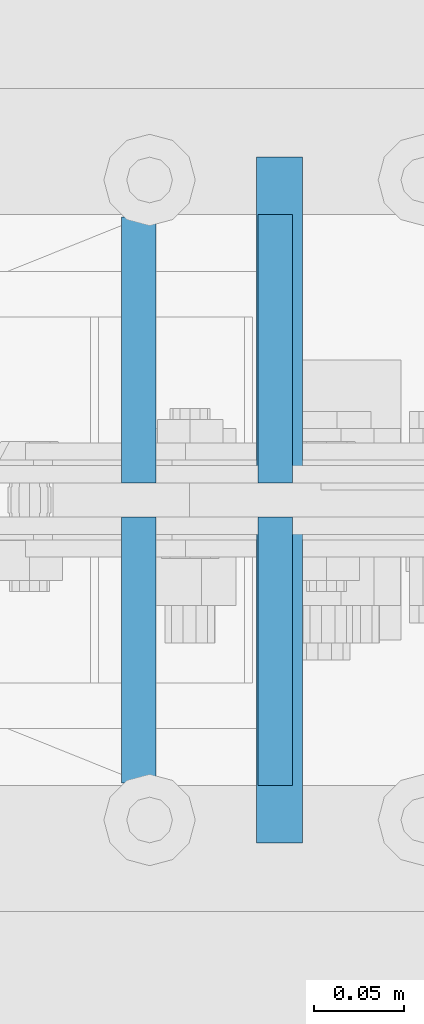
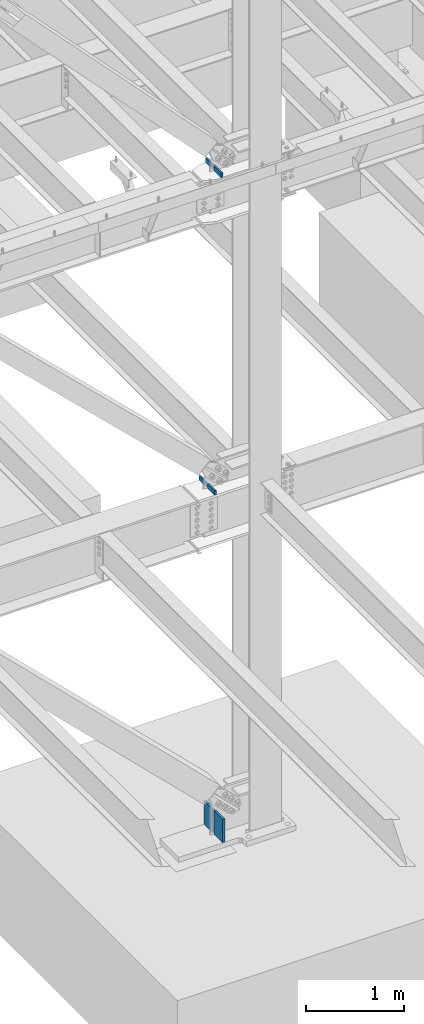
# One storey, part 456 of 1179: 6 columns, 3 elements without a shape of their own.
"""IFC2X3 building model written with IfcOpenShell, lengths in millimetres."""

import ifcopenshell
import ifcopenshell.guid

model = None  # the IFC model being written
_history = None  # IfcOwnerHistory: only IFC2X3 demands one
_inside = {}  # id of a spatial element -> (the spatial element, [elements in it])
_under = {}  # id of a project, library or spatial element -> (it, [spatial elements below it])
_declared = {}  # id of a project -> (the project, [libraries it declares])
_typed = {}  # id of a type object -> (the type object, [elements of that type])
_made_of = {}  # id of a material, layer set ... -> (it, [elements and type objects made of it])


def new_model(schema):
    """Start an empty IFC model of exactly this schema.

    Asked for "IFC4X3", IfcOpenShell would pick the latest addendum, in which some entities
    have other attributes; the version numbers below select the first issue.
    IFC2X3 requires an IfcOwnerHistory on every rooted entity: one is made here for all.
    """
    global model, _history
    if schema == "IFC4X3":
        model = ifcopenshell.file(schema_version=(4, 3, 0, 0))
    else:
        model = ifcopenshell.file(schema=schema)
    _inside.clear()
    _under.clear()
    _declared.clear()
    _typed.clear()
    _made_of.clear()
    _history = None
    if model.schema == "IFC2X3":
        org = make("IfcOrganization", Name="unknown")
        user = make(
            "IfcPersonAndOrganization",
            ThePerson=make("IfcPerson", FamilyName="unknown"),
            TheOrganization=org,
        )
        app = make(
            "IfcApplication",
            ApplicationDeveloper=org,
            Version="unknown",
            ApplicationFullName="unknown",
            ApplicationIdentifier="unknown",
        )
        _history = make(
            "IfcOwnerHistory",
            OwningUser=user,
            OwningApplication=app,
            ChangeAction="ADDED",
            CreationDate=0,
        )
    return model


def make(cls, **values):
    """One entity of the class cls with the attributes given. An attribute that is None is left unset."""
    return model.create_entity(
        cls, **{name: value for name, value in values.items() if value is not None}
    )


def rooted(cls, **values):
    """An entity with a GlobalId (a new one), such as an element, a storey or a relation."""
    return make(cls, GlobalId=ifcopenshell.guid.new(), OwnerHistory=_history, **values)


def si_unit(unit_type, name, prefix=None):
    """IfcSIUnit, for example si_unit("LENGTHUNIT", "METRE", prefix="MILLI")."""
    return make("IfcSIUnit", UnitType=unit_type, Prefix=prefix, Name=name)


def assignment(units):
    """IfcUnitAssignment: the units of a project."""
    return None if units is None else make("IfcUnitAssignment", Units=units)


def point(xyz):
    """IfcCartesianPoint."""
    return None if xyz is None else make("IfcCartesianPoint", Coordinates=xyz)


def direction(xyz):
    """IfcDirection."""
    return None if xyz is None else make("IfcDirection", DirectionRatios=xyz)


def frame(location, z_axis=None, x_axis=None):
    """IfcAxis2Placement3D, a coordinate frame: its origin and axes. An axis left out is left unset."""
    return make(
        "IfcAxis2Placement3D",
        Location=point(location),
        Axis=direction(z_axis),
        RefDirection=direction(x_axis),
    )


def origin_with_axes():
    """The frame at (0, 0, 0) with the z axis (0, 0, 1) and the x axis (1, 0, 0) written out."""
    return frame((0.0, 0.0, 0.0), z_axis=(0.0, 0.0, 1.0), x_axis=(1.0, 0.0, 0.0))


def place(relative_to, where):
    """IfcLocalPlacement: puts the frame where relative to a parent placement (None: the world)."""
    return make(
        "IfcLocalPlacement", PlacementRelTo=relative_to, RelativePlacement=where
    )


def context(
    kind, dimensions, precision=None, world=None, true_north=None, identifier=None
):
    """IfcGeometricRepresentationContext, for example the 3D "Model" context."""
    return make(
        "IfcGeometricRepresentationContext",
        ContextIdentifier=identifier,
        ContextType=kind,
        CoordinateSpaceDimension=dimensions,
        Precision=precision,
        WorldCoordinateSystem=world,
        TrueNorth=true_north,
    )


def subcontext(parent, identifier, kind, view, scale=None):
    """IfcGeometricRepresentationSubContext, for example "Body" below "Model"."""
    return make(
        "IfcGeometricRepresentationSubContext",
        ContextIdentifier=identifier,
        ContextType=kind,
        ParentContext=parent,
        TargetScale=scale,
        TargetView=view,
    )


def project(units=None, contexts=None):
    """IfcProject with its units and contexts."""
    return rooted(
        "IfcProject",
        Name="project",
        RepresentationContexts=contexts,
        UnitsInContext=assignment(units),
    )


def spatial(cls, under=None, at=None, **own):
    """A site, building, storey or space (cls), placed at a placement, below another one or the project."""
    s = rooted(cls, ObjectPlacement=at, **own)
    if under is not None:
        _under.setdefault(under.id(), (under, []))[1].append(s)
    return s


def faces_of(points, faces, orient=None, outer=None):
    """IfcFace entities. A face is a list of loops; a loop is a list of indices into points, from 0.

    orient and outer hold one flag for each loop. By default every Orientation is true, the
    first loop of a face is its IfcFaceOuterBound and the others are IfcFaceBound.
    """
    made = []
    for i, loops in enumerate(faces):
        bounds = []
        for j, loop in enumerate(loops):
            is_outer = j == 0 if outer is None else outer[i][j]
            bounds.append(
                make(
                    "IfcFaceOuterBound" if is_outer else "IfcFaceBound",
                    Bound=make("IfcPolyLoop", Polygon=[points[k] for k in loop]),
                    Orientation=True if orient is None else orient[i][j],
                )
            )
        made.append(make("IfcFace", Bounds=bounds))
    return made


def faceted_brep(points, faces, orient=None, outer=None, voids=None):
    """IfcFacetedBrep: a solid bounded by flat faces; with voids (closed shells), ...WithVoids."""
    shared = [point(p) for p in points]
    hull = make("IfcClosedShell", CfsFaces=faces_of(shared, faces, orient, outer))
    if voids is None:
        return make("IfcFacetedBrep", Outer=hull)
    return make(
        "IfcFacetedBrepWithVoids",
        Outer=hull,
        Voids=[
            make(cls, CfsFaces=faces_of(shared, fs, o, b)) for cls, fs, o, b in voids
        ],
    )


def shape(context_of_items, identifier, shape_type, items):
    """IfcShapeRepresentation: the items that make up one representation, for example the "Body"."""
    return make(
        "IfcShapeRepresentation",
        ContextOfItems=context_of_items,
        RepresentationIdentifier=identifier,
        RepresentationType=shape_type,
        Items=items,
    )


def material(Name=None, Category=None):
    """IfcMaterial."""
    return make("IfcMaterial", Name=Name, Category=Category)


def made_of(thing, what):
    """Note that an element or type object is made of a material, layer set ...; save() writes the relation."""
    if what is not None:
        _made_of.setdefault(what.id(), (what, []))[1].append(thing)
    return thing


def type_object(cls, material=None, **own):
    """A type object (cls), such as IfcWallType, which elements share."""
    return made_of(rooted(cls, **own), material)


def element(
    cls,
    number,
    at=None,
    inside=None,
    cuts=None,
    type_object=None,
    material=None,
    context=None,
    identifier="Body",
    shape_type=None,
    held_by="IfcProductDefinitionShape",
    body=None,
    shapes=None,
    **own,
):
    """One element of the class cls, such as IfcWall. Its Tag is "e" and its number.

    at: its placement. inside: the storey or other place that contains it. cuts: it is an
    opening in that element (IfcRelVoidsElement). A single representation is given by context,
    identifier, shape_type and body (its items); several are given by shapes. held_by: the class
    of the entity that holds the representations. save() writes the other relations.
    """
    e = rooted(cls, Tag="e%d" % number, ObjectPlacement=at, **own)
    if body is not None:
        shapes = [shape(context, identifier, shape_type, body)]
    if shapes is not None:
        e.Representation = make(held_by, Representations=shapes)
    if inside is not None:
        _inside.setdefault(inside.id(), (inside, []))[1].append(e)
    if cuts is not None:
        rooted(
            "IfcRelVoidsElement", RelatingBuildingElement=cuts, RelatedOpeningElement=e
        )
    if type_object is not None:
        _typed.setdefault(type_object.id(), (type_object, []))[1].append(e)
    return made_of(e, material)


def aggregate(whole, parts):
    """IfcRelAggregates: a whole, such as a stair, and the parts it consists of."""
    return rooted("IfcRelAggregates", RelatingObject=whole, RelatedObjects=parts)


def save(model, path):
    """Write the relations noted so far, then the file.

    IfcRelAggregates (storeys below a building ...), IfcRelContainedInSpatialStructure (elements
    in a storey), IfcRelDefinesByType, IfcRelAssociatesMaterial and IfcRelDeclares: one each for
    every whole, place, type object, material and project.
    """
    for whole, parts in _under.values():
        aggregate(whole, parts)
    for where, things in _inside.values():
        rooted(
            "IfcRelContainedInSpatialStructure",
            RelatedElements=things,
            RelatingStructure=where,
        )
    for kind, things in _typed.values():
        rooted("IfcRelDefinesByType", RelatedObjects=things, RelatingType=kind)
    for what, things in _made_of.values():
        rooted("IfcRelAssociatesMaterial", RelatedObjects=things, RelatingMaterial=what)
    for by, libraries in _declared.values():
        rooted("IfcRelDeclares", RelatingContext=by, RelatedDefinitions=libraries)
    model.write(path)


model = new_model("IFC2X3")

# Units and contexts
model_context = context("Model", 3, precision=1e-05, world=origin_with_axes())
body_context = subcontext(model_context, "Body", "Model", "MODEL_VIEW")
ifc_project = project(units=[si_unit("LENGTHUNIT", "METRE", prefix="MILLI"), si_unit("AREAUNIT", "SQUARE_METRE"), si_unit("VOLUMEUNIT", "CUBIC_METRE"), si_unit("MASSUNIT", "GRAM", prefix="KILO"), si_unit("TIMEUNIT", "SECOND"), si_unit("PLANEANGLEUNIT", "RADIAN"), si_unit("SOLIDANGLEUNIT", "STERADIAN"), si_unit("THERMODYNAMICTEMPERATUREUNIT", "DEGREE_CELSIUS"), si_unit("LUMINOUSINTENSITYUNIT", "LUMEN")], contexts=[model_context])

# Site, building, storey
site_placement = place(None, origin_with_axes())
site = spatial("IfcSite", under=ifc_project, at=site_placement, CompositionType="ELEMENT")
building_placement = place(site_placement, origin_with_axes())
building = spatial("IfcBuilding", under=site, at=building_placement, Name="Undefined", CompositionType="ELEMENT")
storey_placement = place(building_placement, origin_with_axes())
storey = spatial("IfcBuildingStorey", under=building, at=storey_placement, Name="Undefined", CompositionType="ELEMENT", Elevation=0.0)

# Assembly, columns
assembly_1_placement = place(storey_placement, origin_with_axes())
assembly_1 = element("IfcElementAssembly", 1, at=assembly_1_placement, inside=storey, Name="COLUMN", AssemblyPlace="NOTDEFINED", PredefinedType="RIGID_FRAME")
ifc_material = material(Name="STEEL/A572-GR.50")
column_type_1 = type_object("IfcColumnType", PredefinedType="NOTDEFINED")
column_1_placement = place(assembly_1_placement, frame((15881.7129892222, 26967.6562863882, 4102.1), z_axis=(0.0, 1.0, 0.0), x_axis=(0.0, 0.0, 1.0)))
column_1 = element("IfcColumn", 2, at=column_1_placement, type_object=column_type_1, material=ifc_material, Name="PLATE", context=body_context, shape_type="Brep", body=[
    faceted_brep([(0.0, 9.52499999999964, -73.8189999999995), (0.0, 9.52499999999964, 73.8189999999995), (51.3564167127251, 9.52499999999964, 73.8189999999995), (51.3564167127251, 9.52499999999964, -73.8189999999995), (0.0, -9.52499999999964, 73.8189999999995), (51.3564167127251, -9.52499999999964, 73.8189999999995), (0.0, -9.52499999999964, -73.8189999999995), (51.3564167127251, -9.52499999999964, -73.8189999999995)], [[[0, 1, 2, 3]], [[1, 4, 5, 2]], [[4, 6, 7, 5]], [[6, 0, 3, 7]], [[5, 7, 3, 2]], [[6, 4, 1, 0]]]),
])
column_2_placement = place(assembly_1_placement, frame((15881.7129892222, 27134.3437136118, 4102.1), z_axis=(0.0, -1.0, 0.0), x_axis=(0.0, 0.0, 1.0)))
column_2 = element("IfcColumn", 3, at=column_2_placement, type_object=column_type_1, material=ifc_material, Name="PLATE", context=body_context, shape_type="Brep", body=[
    faceted_brep([(0.0, 9.52499999999964, -73.8189999999995), (0.0, 9.52499999999964, 73.8189999999995), (51.3564167127251, 9.52499999999964, 73.8189999999995), (51.3564167127251, 9.52499999999964, -73.8189999999995), (0.0, -9.52499999999964, 73.8189999999995), (51.3564167127251, -9.52499999999964, 73.8189999999995), (0.0, -9.52499999999964, -73.8189999999995), (51.3564167127251, -9.52499999999964, -73.8189999999995)], [[[0, 1, 2, 3]], [[1, 4, 5, 2]], [[4, 6, 7, 5]], [[6, 0, 3, 7]], [[5, 7, 3, 2]], [[6, 4, 1, 0]]]),
])

# Assembly, column
assembly_2_placement = place(storey_placement, origin_with_axes())
assembly_2 = element("IfcElementAssembly", 4, at=assembly_2_placement, inside=storey, Name="PLATE", AssemblyPlace="NOTDEFINED", PredefinedType="RIGID_FRAME")
column_type_2 = type_object("IfcColumnType", PredefinedType="NOTDEFINED")
column_3_placement = place(assembly_2_placement, frame((15959.8778558538, 27152.6, -215.9), z_axis=(0.0, -1.0, 0.0), x_axis=(0.0, 0.0, 1.0)))
column_3 = element("IfcColumn", 5, at=column_3_placement, type_object=column_type_2, material=ifc_material, Name="PLATE", context=body_context, shape_type="Brep", body=[
    faceted_brep([(0.0, 12.6999999999998, -88.9000000000015), (0.0, 12.6999999999998, 88.9000000000015), (291.683174367477, 12.7000000000007, 88.9000000000015), (291.683174367477, 12.7000000000007, -88.9000000000015), (0.0, -12.6999999999998, 88.9000000000015), (291.683174367477, -12.7000000000007, 88.9000000000015), (0.0, -12.6999999999998, -88.9000000000015), (291.683174367477, -12.7000000000007, -88.9000000000015)], [[[0, 1, 2, 3]], [[1, 4, 5, 2]], [[4, 6, 7, 5]], [[6, 0, 3, 7]], [[5, 7, 3, 2]], [[6, 4, 1, 0]]]),
])
aggregate(assembly_2, [column_3])

assembly_3_placement = place(storey_placement, origin_with_axes())
assembly_3 = element("IfcElementAssembly", 6, at=assembly_3_placement, inside=storey, Name="PLATE", AssemblyPlace="NOTDEFINED", PredefinedType="RIGID_FRAME")
column_4_placement = place(assembly_3_placement, frame((15959.8778558538, 26949.4, -215.9), z_axis=(0.0, 1.0, 0.0), x_axis=(0.0, 0.0, 1.0)))
column_4 = element("IfcColumn", 7, at=column_4_placement, type_object=column_type_2, material=ifc_material, Name="PLATE", context=body_context, shape_type="Brep", body=[
    faceted_brep([(0.0, 12.6999999999998, -88.9000000000015), (0.0, 12.6999999999998, 88.9000000000015), (291.683174367477, 12.7000000000007, 88.9000000000015), (291.683174367477, 12.7000000000007, -88.9000000000015), (0.0, -12.6999999999998, 88.9000000000015), (291.683174367477, -12.7000000000007, 88.9000000000015), (0.0, -12.6999999999998, -88.9000000000015), (291.683174367477, -12.7000000000007, -88.9000000000015)], [[[0, 1, 2, 3]], [[1, 4, 5, 2]], [[4, 6, 7, 5]], [[6, 0, 3, 7]], [[5, 7, 3, 2]], [[6, 4, 1, 0]]]),
])
aggregate(assembly_3, [column_4])

# Column
column_type_3 = type_object("IfcColumnType", PredefinedType="NOTDEFINED")
column_5_placement = place(assembly_1_placement, frame((15957.5410799851, 27135.1375, 8013.7), z_axis=(0.0, -1.0, 0.0), x_axis=(0.0, 0.0, 1.0)))
column_5 = element("IfcColumn", 8, at=column_5_placement, type_object=column_type_3, material=ifc_material, Name="PLATE", context=body_context, shape_type="Brep", body=[
    faceted_brep([(0.0, 9.52499999999964, -74.6124999999993), (0.0, 9.52499999999964, 74.6124999999993), (58.2260027054381, 9.52499999999964, 74.6124999999993), (58.2260027054381, 9.52499999999964, -74.6124999999993), (0.0, -9.52499999999964, 74.6124999999993), (58.2260027054381, -9.52499999999964, 74.6124999999993), (0.0, -9.52499999999964, -74.6124999999993), (58.2260027054381, -9.52499999999964, -74.6124999999993)], [[[0, 1, 2, 3]], [[1, 4, 5, 2]], [[4, 6, 7, 5]], [[6, 0, 3, 7]], [[5, 7, 3, 2]], [[6, 4, 1, 0]]]),
])

column_6_placement = place(assembly_1_placement, frame((15957.5410799851, 26966.8625, 8013.7), z_axis=(0.0, 1.0, 0.0), x_axis=(0.0, 0.0, 1.0)))
column_6 = element("IfcColumn", 9, at=column_6_placement, type_object=column_type_3, material=ifc_material, Name="PLATE", context=body_context, shape_type="Brep", body=[
    faceted_brep([(0.0, 9.52499999999964, -74.6124999999993), (0.0, 9.52499999999964, 74.6124999999993), (58.2260027054381, 9.52499999999964, 74.6124999999993), (58.2260027054381, 9.52499999999964, -74.6124999999993), (0.0, -9.52499999999964, 74.6124999999993), (58.2260027054381, -9.52499999999964, 74.6124999999993), (0.0, -9.52499999999964, -74.6124999999993), (58.2260027054381, -9.52499999999964, -74.6124999999993)], [[[0, 1, 2, 3]], [[1, 4, 5, 2]], [[4, 6, 7, 5]], [[6, 0, 3, 7]], [[5, 7, 3, 2]], [[6, 4, 1, 0]]]),
])

aggregate(assembly_1, [column_1, column_2, column_5, column_6])

save(model, "model.ifc")
